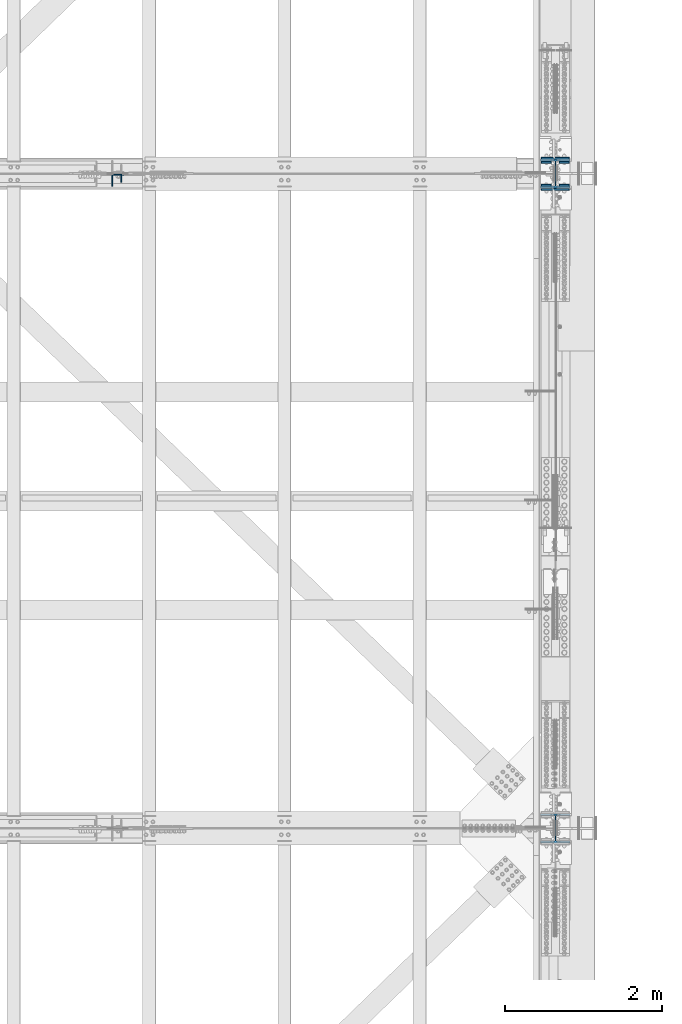
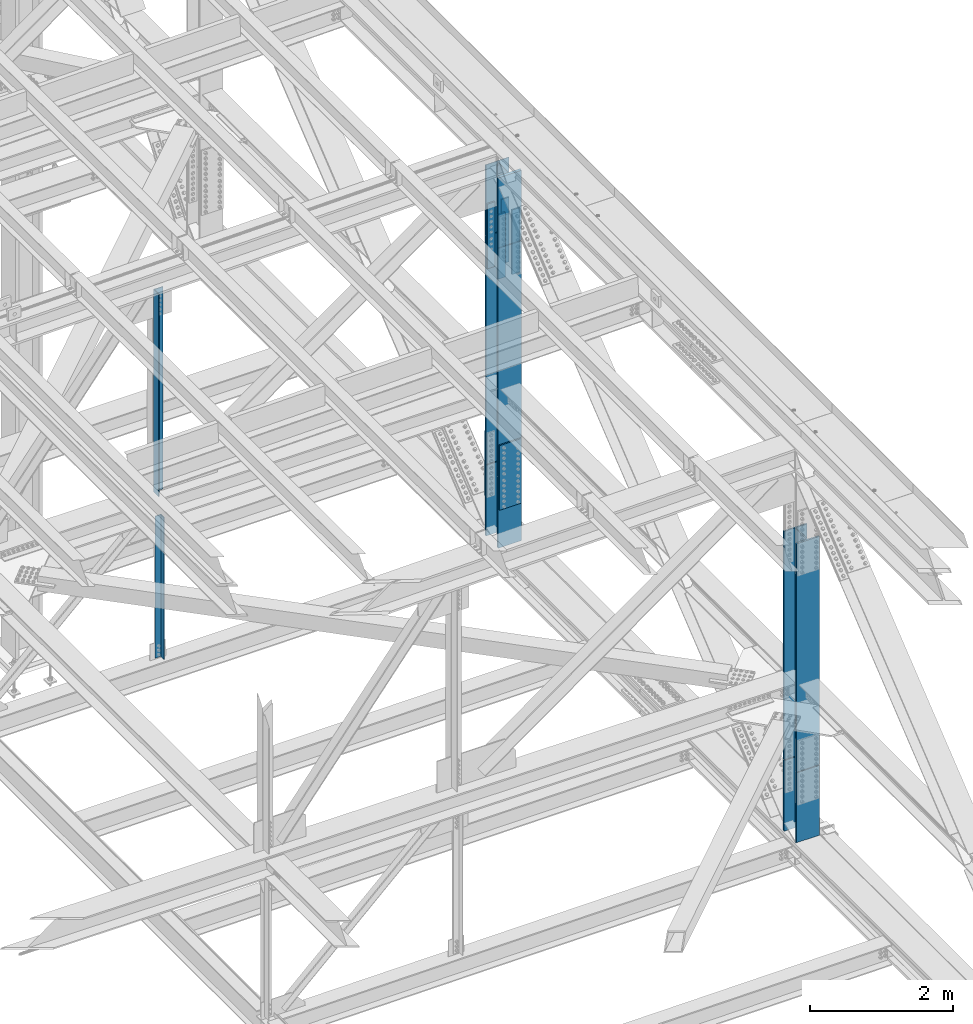
# One storey, part 1420 of 3843: 13 columns, 7 elements without a shape of their own.
"""IFC2X3 building model written with IfcOpenShell, lengths in millimetres."""

import ifcopenshell
import ifcopenshell.guid

model = None  # the IFC model being written
_history = None  # IfcOwnerHistory: only IFC2X3 demands one
_inside = {}  # id of a spatial element -> (the spatial element, [elements in it])
_under = {}  # id of a project, library or spatial element -> (it, [spatial elements below it])
_declared = {}  # id of a project -> (the project, [libraries it declares])
_typed = {}  # id of a type object -> (the type object, [elements of that type])
_made_of = {}  # id of a material, layer set ... -> (it, [elements and type objects made of it])


def new_model(schema):
    """Start an empty IFC model of exactly this schema.

    Asked for "IFC4X3", IfcOpenShell would pick the latest addendum, in which some entities
    have other attributes; the version numbers below select the first issue.
    IFC2X3 requires an IfcOwnerHistory on every rooted entity: one is made here for all.
    """
    global model, _history
    if schema == "IFC4X3":
        model = ifcopenshell.file(schema_version=(4, 3, 0, 0))
    else:
        model = ifcopenshell.file(schema=schema)
    _inside.clear()
    _under.clear()
    _declared.clear()
    _typed.clear()
    _made_of.clear()
    _history = None
    if model.schema == "IFC2X3":
        org = make("IfcOrganization", Name="unknown")
        user = make(
            "IfcPersonAndOrganization",
            ThePerson=make("IfcPerson", FamilyName="unknown"),
            TheOrganization=org,
        )
        app = make(
            "IfcApplication",
            ApplicationDeveloper=org,
            Version="unknown",
            ApplicationFullName="unknown",
            ApplicationIdentifier="unknown",
        )
        _history = make(
            "IfcOwnerHistory",
            OwningUser=user,
            OwningApplication=app,
            ChangeAction="ADDED",
            CreationDate=0,
        )
    return model


def make(cls, **values):
    """One entity of the class cls with the attributes given. An attribute that is None is left unset."""
    return model.create_entity(
        cls, **{name: value for name, value in values.items() if value is not None}
    )


def rooted(cls, **values):
    """An entity with a GlobalId (a new one), such as an element, a storey or a relation."""
    return make(cls, GlobalId=ifcopenshell.guid.new(), OwnerHistory=_history, **values)


def si_unit(unit_type, name, prefix=None):
    """IfcSIUnit, for example si_unit("LENGTHUNIT", "METRE", prefix="MILLI")."""
    return make("IfcSIUnit", UnitType=unit_type, Prefix=prefix, Name=name)


def assignment(units):
    """IfcUnitAssignment: the units of a project."""
    return None if units is None else make("IfcUnitAssignment", Units=units)


def point(xyz):
    """IfcCartesianPoint."""
    return None if xyz is None else make("IfcCartesianPoint", Coordinates=xyz)


def direction(xyz):
    """IfcDirection."""
    return None if xyz is None else make("IfcDirection", DirectionRatios=xyz)


def frame(location, z_axis=None, x_axis=None):
    """IfcAxis2Placement3D, a coordinate frame: its origin and axes. An axis left out is left unset."""
    return make(
        "IfcAxis2Placement3D",
        Location=point(location),
        Axis=direction(z_axis),
        RefDirection=direction(x_axis),
    )


def origin_with_axes():
    """The frame at (0, 0, 0) with the z axis (0, 0, 1) and the x axis (1, 0, 0) written out."""
    return frame((0.0, 0.0, 0.0), z_axis=(0.0, 0.0, 1.0), x_axis=(1.0, 0.0, 0.0))


def place(relative_to, where):
    """IfcLocalPlacement: puts the frame where relative to a parent placement (None: the world)."""
    return make(
        "IfcLocalPlacement", PlacementRelTo=relative_to, RelativePlacement=where
    )


def context(
    kind, dimensions, precision=None, world=None, true_north=None, identifier=None
):
    """IfcGeometricRepresentationContext, for example the 3D "Model" context."""
    return make(
        "IfcGeometricRepresentationContext",
        ContextIdentifier=identifier,
        ContextType=kind,
        CoordinateSpaceDimension=dimensions,
        Precision=precision,
        WorldCoordinateSystem=world,
        TrueNorth=true_north,
    )


def subcontext(parent, identifier, kind, view, scale=None):
    """IfcGeometricRepresentationSubContext, for example "Body" below "Model"."""
    return make(
        "IfcGeometricRepresentationSubContext",
        ContextIdentifier=identifier,
        ContextType=kind,
        ParentContext=parent,
        TargetScale=scale,
        TargetView=view,
    )


def project(units=None, contexts=None):
    """IfcProject with its units and contexts."""
    return rooted(
        "IfcProject",
        Name="project",
        RepresentationContexts=contexts,
        UnitsInContext=assignment(units),
    )


def spatial(cls, under=None, at=None, **own):
    """A site, building, storey or space (cls), placed at a placement, below another one or the project."""
    s = rooted(cls, ObjectPlacement=at, **own)
    if under is not None:
        _under.setdefault(under.id(), (under, []))[1].append(s)
    return s


def faces_of(points, faces, orient=None, outer=None):
    """IfcFace entities. A face is a list of loops; a loop is a list of indices into points, from 0.

    orient and outer hold one flag for each loop. By default every Orientation is true, the
    first loop of a face is its IfcFaceOuterBound and the others are IfcFaceBound.
    """
    made = []
    for i, loops in enumerate(faces):
        bounds = []
        for j, loop in enumerate(loops):
            is_outer = j == 0 if outer is None else outer[i][j]
            bounds.append(
                make(
                    "IfcFaceOuterBound" if is_outer else "IfcFaceBound",
                    Bound=make("IfcPolyLoop", Polygon=[points[k] for k in loop]),
                    Orientation=True if orient is None else orient[i][j],
                )
            )
        made.append(make("IfcFace", Bounds=bounds))
    return made


def faceted_brep(points, faces, orient=None, outer=None, voids=None):
    """IfcFacetedBrep: a solid bounded by flat faces; with voids (closed shells), ...WithVoids."""
    shared = [point(p) for p in points]
    hull = make("IfcClosedShell", CfsFaces=faces_of(shared, faces, orient, outer))
    if voids is None:
        return make("IfcFacetedBrep", Outer=hull)
    return make(
        "IfcFacetedBrepWithVoids",
        Outer=hull,
        Voids=[
            make(cls, CfsFaces=faces_of(shared, fs, o, b)) for cls, fs, o, b in voids
        ],
    )


def shape(context_of_items, identifier, shape_type, items):
    """IfcShapeRepresentation: the items that make up one representation, for example the "Body"."""
    return make(
        "IfcShapeRepresentation",
        ContextOfItems=context_of_items,
        RepresentationIdentifier=identifier,
        RepresentationType=shape_type,
        Items=items,
    )


def material(Name=None, Category=None):
    """IfcMaterial."""
    return make("IfcMaterial", Name=Name, Category=Category)


def made_of(thing, what):
    """Note that an element or type object is made of a material, layer set ...; save() writes the relation."""
    if what is not None:
        _made_of.setdefault(what.id(), (what, []))[1].append(thing)
    return thing


def type_object(cls, material=None, **own):
    """A type object (cls), such as IfcWallType, which elements share."""
    return made_of(rooted(cls, **own), material)


def element(
    cls,
    number,
    at=None,
    inside=None,
    cuts=None,
    type_object=None,
    material=None,
    context=None,
    identifier="Body",
    shape_type=None,
    held_by="IfcProductDefinitionShape",
    body=None,
    shapes=None,
    **own,
):
    """One element of the class cls, such as IfcWall. Its Tag is "e" and its number.

    at: its placement. inside: the storey or other place that contains it. cuts: it is an
    opening in that element (IfcRelVoidsElement). A single representation is given by context,
    identifier, shape_type and body (its items); several are given by shapes. held_by: the class
    of the entity that holds the representations. save() writes the other relations.
    """
    e = rooted(cls, Tag="e%d" % number, ObjectPlacement=at, **own)
    if body is not None:
        shapes = [shape(context, identifier, shape_type, body)]
    if shapes is not None:
        e.Representation = make(held_by, Representations=shapes)
    if inside is not None:
        _inside.setdefault(inside.id(), (inside, []))[1].append(e)
    if cuts is not None:
        rooted(
            "IfcRelVoidsElement", RelatingBuildingElement=cuts, RelatedOpeningElement=e
        )
    if type_object is not None:
        _typed.setdefault(type_object.id(), (type_object, []))[1].append(e)
    return made_of(e, material)


def aggregate(whole, parts):
    """IfcRelAggregates: a whole, such as a stair, and the parts it consists of."""
    return rooted("IfcRelAggregates", RelatingObject=whole, RelatedObjects=parts)


def save(model, path):
    """Write the relations noted so far, then the file.

    IfcRelAggregates (storeys below a building ...), IfcRelContainedInSpatialStructure (elements
    in a storey), IfcRelDefinesByType, IfcRelAssociatesMaterial and IfcRelDeclares: one each for
    every whole, place, type object, material and project.
    """
    for whole, parts in _under.values():
        aggregate(whole, parts)
    for where, things in _inside.values():
        rooted(
            "IfcRelContainedInSpatialStructure",
            RelatedElements=things,
            RelatingStructure=where,
        )
    for kind, things in _typed.values():
        rooted("IfcRelDefinesByType", RelatedObjects=things, RelatingType=kind)
    for what, things in _made_of.values():
        rooted("IfcRelAssociatesMaterial", RelatedObjects=things, RelatingMaterial=what)
    for by, libraries in _declared.values():
        rooted("IfcRelDeclares", RelatingContext=by, RelatedDefinitions=libraries)
    model.write(path)


model = new_model("IFC2X3")

# Units and contexts
model_context = context("Model", 3, precision=1e-05, world=origin_with_axes())
body_context = subcontext(model_context, "Body", "Model", "MODEL_VIEW")
ifc_project = project(units=[si_unit("LENGTHUNIT", "METRE", prefix="MILLI"), si_unit("AREAUNIT", "SQUARE_METRE"), si_unit("VOLUMEUNIT", "CUBIC_METRE"), si_unit("MASSUNIT", "GRAM", prefix="KILO"), si_unit("TIMEUNIT", "SECOND"), si_unit("PLANEANGLEUNIT", "RADIAN"), si_unit("SOLIDANGLEUNIT", "STERADIAN"), si_unit("THERMODYNAMICTEMPERATUREUNIT", "DEGREE_CELSIUS"), si_unit("LUMINOUSINTENSITYUNIT", "LUMEN")], contexts=[model_context])

# Site, building, storey
site_placement = place(None, origin_with_axes())
site = spatial("IfcSite", under=ifc_project, at=site_placement, CompositionType="ELEMENT")
building_placement = place(site_placement, origin_with_axes())
building = spatial("IfcBuilding", under=site, at=building_placement, Name="Undefined", CompositionType="ELEMENT")
storey_placement = place(building_placement, origin_with_axes())
storey = spatial("IfcBuildingStorey", under=building, at=storey_placement, Name="Undefined", CompositionType="ELEMENT", Elevation=0.0)

# Assembly, column
assembly_1_placement = place(storey_placement, origin_with_axes())
assembly_1 = element("IfcElementAssembly", 1, at=assembly_1_placement, inside=storey, Name="ANGLE", AssemblyPlace="NOTDEFINED", PredefinedType="RIGID_FRAME")
ifc_material_1 = material(Name="STEEL/A572-50")
column_type_1 = type_object("IfcColumnType", Name="L4X4X3/8", PredefinedType="NOTDEFINED")
column_1_placement = place(assembly_1_placement, frame((80060.7999999579, 75568.175, 39465.2385299534), z_axis=(-1.0, 0.0, 0.0), x_axis=(0.0, 0.0, 1.0)))
column_1 = element("IfcColumn", 2, at=column_1_placement, type_object=column_type_1, material=ifc_material_1, Name="ANGLE", ObjectType="L4X4X3/8", context=body_context, shape_type="Brep", body=[
    faceted_brep([(203.510731785107, 50.8000000000029, -50.8000000000029), (203.510731785107, 50.8000000000029, 50.8000000000029), (2631.72677430857, 50.8000000000029, 50.8000000000029), (2631.72677430857, 50.8000000000029, -50.8000000000029), (203.510731785107, 41.2749999999942, 50.8000000000029), (2631.72677430857, 41.2749999999942, 50.8000000000029), (203.510731785107, 41.2749999999942, -41.2749999999942), (2631.72677430857, 41.2749999999942, -41.2749999999942), (203.510731785107, -50.8000000000029, -41.2749999999942), (2631.72677430857, -50.8000000000029, -41.2749999999942), (203.510731785107, -50.8000000000029, -50.8000000000029), (2631.72677430857, -50.8000000000029, -50.8000000000029)], [[[0, 1, 2, 3]], [[1, 4, 5, 2]], [[4, 6, 7, 5]], [[6, 8, 9, 7]], [[8, 10, 11, 9]], [[10, 0, 3, 11]], [[5, 7, 9, 11, 3, 2]], [[10, 8, 6, 4, 1, 0]]]),
])
aggregate(assembly_1, [column_1])

# Assembly, columns
assembly_2_placement = place(storey_placement, origin_with_axes())
assembly_2 = element("IfcElementAssembly", 3, at=assembly_2_placement, inside=storey, Name="BEAM", AssemblyPlace="NOTDEFINED", PredefinedType="RIGID_FRAME")
column_type_2 = type_object("IfcColumnType", PredefinedType="NOTDEFINED")
column_2_placement = place(assembly_2_placement, frame((85534.5, 75480.8623822225, 44321.8444674401), z_axis=(1.0, 0.0, 0.0), x_axis=(0.0, 0.0, 1.0)))
column_2 = element("IfcColumn", 4, at=column_2_placement, type_object=column_type_2, material=ifc_material_1, Name="PLATE", context=body_context, shape_type="Brep", body=[
    faceted_brep([(-4.36557456851006e-11, 12.7000000000116, -63.5), (-4.36557456851006e-11, 12.7000000000116, 63.5), (1104.90000001677, 12.7000000017251, 63.5), (1104.90000001677, 12.7000000017251, -63.5), (1.45519152283669e-11, -12.700000000008, 63.5), (1104.90000001682, -12.6999999982909, 63.5), (1.45519152283669e-11, -12.700000000008, -63.5), (1104.90000001682, -12.6999999982909, -63.5)], [[[0, 1, 2, 3]], [[1, 4, 5, 2]], [[4, 6, 7, 5]], [[6, 0, 3, 7]], [[5, 7, 3, 2]], [[6, 4, 1, 0]]]),
])
column_3_placement = place(assembly_2_placement, frame((85534.5, 75776.1373007486, 44321.8444376159), z_axis=(1.0, 0.0, 0.0), x_axis=(0.0, 0.0, 1.0)))
column_3 = element("IfcColumn", 5, at=column_3_placement, type_object=column_type_2, material=ifc_material_1, Name="PLATE", context=body_context, shape_type="Brep", body=[
    faceted_brep([(-4.36557456851006e-11, 12.7000000000116, -63.5), (-4.36557456851006e-11, 12.7000000000116, 63.5), (1104.90000001677, 12.7000000017251, 63.5), (1104.90000001677, 12.7000000017251, -63.5), (1.45519152283669e-11, -12.700000000008, 63.5), (1104.90000001682, -12.6999999982909, 63.5), (1.45519152283669e-11, -12.700000000008, -63.5), (1104.90000001682, -12.6999999982909, -63.5)], [[[0, 1, 2, 3]], [[1, 4, 5, 2]], [[4, 6, 7, 5]], [[6, 0, 3, 7]], [[5, 7, 3, 2]], [[6, 4, 1, 0]]]),
])
column_4_placement = place(assembly_2_placement, frame((85763.1, 75480.8623822225, 44321.8444674401), z_axis=(1.0, 0.0, 0.0), x_axis=(0.0, 0.0, 1.0)))
column_4 = element("IfcColumn", 6, at=column_4_placement, type_object=column_type_2, material=ifc_material_1, Name="PLATE", context=body_context, shape_type="Brep", body=[
    faceted_brep([(-4.36557456851006e-11, 12.7000000000116, -63.5), (-4.36557456851006e-11, 12.7000000000116, 63.5), (1104.90000001677, 12.7000000017251, 63.5), (1104.90000001677, 12.7000000017251, -63.5), (1.45519152283669e-11, -12.700000000008, 63.5), (1104.90000001682, -12.6999999982909, 63.5), (1.45519152283669e-11, -12.700000000008, -63.5), (1104.90000001682, -12.6999999982909, -63.5)], [[[0, 1, 2, 3]], [[1, 4, 5, 2]], [[4, 6, 7, 5]], [[6, 0, 3, 7]], [[5, 7, 3, 2]], [[6, 4, 1, 0]]]),
])
column_5_placement = place(assembly_2_placement, frame((85763.1, 75776.1373059021, 44321.8444376159), z_axis=(1.0, 0.0, 0.0), x_axis=(0.0, 0.0, 1.0)))
column_5 = element("IfcColumn", 7, at=column_5_placement, type_object=column_type_2, material=ifc_material_1, Name="PLATE", context=body_context, shape_type="Brep", body=[
    faceted_brep([(-4.36557456851006e-11, 12.7000000000116, -63.5), (-4.36557456851006e-11, 12.7000000000116, 63.5), (1104.90000001677, 12.7000000017251, 63.5), (1104.90000001677, 12.7000000017251, -63.5), (1.45519152283669e-11, -12.700000000008, 63.5), (1104.90000001682, -12.6999999982909, 63.5), (1.45519152283669e-11, -12.700000000008, -63.5), (1104.90000001682, -12.6999999982909, -63.5)], [[[0, 1, 2, 3]], [[1, 4, 5, 2]], [[4, 6, 7, 5]], [[6, 0, 3, 7]], [[5, 7, 3, 2]], [[6, 4, 1, 0]]]),
])

# Assembly, column
assembly_3_placement = place(storey_placement, origin_with_axes())
assembly_3 = element("IfcElementAssembly", 8, at=assembly_3_placement, inside=storey, Name="ANGLE", AssemblyPlace="NOTDEFINED", PredefinedType="RIGID_FRAME")
column_type_3 = type_object("IfcColumnType", Name="L6X6X1/2", PredefinedType="NOTDEFINED")
column_6_placement = place(assembly_3_placement, frame((80060.8, 75542.775, 42313.9416734368), z_axis=(0.0, -1.0, 0.0), x_axis=(0.0, 0.0, 1.0)))
column_6 = element("IfcColumn", 9, at=column_6_placement, type_object=column_type_3, material=ifc_material_1, Name="ANGLE", ObjectType="L6X6X1/2", context=body_context, shape_type="Brep", body=[
    faceted_brep([(210.389274784269, 76.1999999999971, -76.1999999999971), (210.389274784269, 76.1999999999971, 76.1999999999971), (3669.54954076916, 76.1999999999971, 76.1999999999971), (3669.54954076916, 76.1999999999971, -76.1999999999971), (210.389274784269, 63.5, 76.1999999999971), (3669.54954076916, 63.5, 76.1999999999971), (210.389274784269, 63.5, -63.5), (3669.54954076916, 63.5, -63.5), (210.389274784269, -76.1999999999971, -63.5), (3669.54954076916, -76.1999999999971, -63.5), (210.389274784269, -76.1999999999971, -76.1999999999971), (3669.54954076916, -76.1999999999971, -76.1999999999971)], [[[0, 1, 2, 3]], [[1, 4, 5, 2]], [[4, 6, 7, 5]], [[6, 8, 9, 7]], [[8, 10, 11, 9]], [[10, 0, 3, 11]], [[5, 7, 9, 11, 3, 2]], [[10, 8, 6, 4, 1, 0]]]),
])
aggregate(assembly_3, [column_6])

# Assembly, columns
assembly_4_placement = place(storey_placement, origin_with_axes())
assembly_4 = element("IfcElementAssembly", 10, at=assembly_4_placement, inside=storey, Name="BEAM", AssemblyPlace="NOTDEFINED", PredefinedType="RIGID_FRAME")
column_type_4 = type_object("IfcColumnType", PredefinedType="NOTDEFINED")
column_7_placement = place(assembly_4_placement, frame((85648.8, 75430.0625000002, 40403.8839713305), z_axis=(-1.0, 0.0, 0.0), x_axis=(0.0, 0.0, 1.0)))
column_7 = element("IfcColumn", 11, at=column_7_placement, type_object=column_type_4, material=ifc_material_1, Name="PLATE", context=body_context, shape_type="Brep", body=[
    faceted_brep([(-1.45519152283669e-11, 12.7000000000025, -177.800000000003), (-1.45519152283669e-11, 12.7000000000025, 177.800000000003), (1104.90000001682, 12.7000000017051, 177.800000000003), (1104.90000001682, 12.7000000017051, -177.800000000003), (4.36557456851006e-11, -12.7000000000171, 177.800000000003), (1104.90000001686, -12.6999999983072, 177.800000000003), (4.36557456851006e-11, -12.7000000000171, -177.800000000003), (1104.90000001686, -12.6999999983072, -177.800000000003)], [[[0, 1, 2, 3]], [[1, 4, 5, 2]], [[4, 6, 7, 5]], [[6, 0, 3, 7]], [[5, 7, 3, 2]], [[6, 4, 1, 0]]]),
])
column_8_placement = place(assembly_4_placement, frame((85648.8, 75826.9375000002, 40403.8839713305), z_axis=(-1.0, 0.0, 0.0), x_axis=(0.0, 0.0, 1.0)))
column_8 = element("IfcColumn", 12, at=column_8_placement, type_object=column_type_4, material=ifc_material_1, Name="PLATE", context=body_context, shape_type="Brep", body=[
    faceted_brep([(-1.45519152283669e-11, 12.7000000000025, -177.800000000003), (-1.45519152283669e-11, 12.7000000000025, 177.800000000003), (1104.90000001682, 12.7000000017051, 177.800000000003), (1104.90000001682, 12.7000000017051, -177.800000000003), (4.36557456851006e-11, -12.7000000000171, 177.800000000003), (1104.90000001686, -12.6999999983072, 177.800000000003), (4.36557456851006e-11, -12.7000000000171, -177.800000000003), (1104.90000001686, -12.6999999983072, -177.800000000003)], [[[0, 1, 2, 3]], [[1, 4, 5, 2]], [[4, 6, 7, 5]], [[6, 0, 3, 7]], [[5, 7, 3, 2]], [[6, 4, 1, 0]]]),
])

# Column
ifc_material_2 = material(Name="STEEL/A992")
column_type_5 = type_object("IfcColumnType", Name="W14X132", PredefinedType="NOTDEFINED")
column_9_placement = place(assembly_2_placement, frame((85648.8, 75628.4998616975, 44874.294452528), z_axis=(0.0, 1.0, 0.0), x_axis=(0.0, 0.0, 1.0)))
column_9 = element("IfcColumn", 13, at=column_9_placement, type_object=column_type_5, material=ifc_material_2, Name="COLUMN", ObjectType="W14X132", context=body_context, shape_type="Brep", body=[
    faceted_brep([(1163.47275046445, 187.324999999997, -160.337499994377), (6.34999999999854, 187.324999999997, -160.337499999994), (6.34999999999854, 7.9375, -160.337499999994), (1163.47275046445, 7.9375, -160.337499994377), (1216.25693175628, 7.9375, -160.337499994115), (1216.25693175628, 187.324999999997, -160.337499994115), (1163.25387339722, 187.324999999997, 160.337500005626), (6.34999999999854, 187.324999999997, 160.337499999994), (6.34999999999854, 187.324999999997, 185.737500000003), (1201.32087227298, 187.324999999997, 185.737500005795), (1215.83975002835, 187.324999999997, 160.337500005873), (1163.25387339722, 7.9375, 160.337500005626), (6.34999999999854, 7.9375, 160.337499999994), (1215.83975002835, 7.9375, 160.337500005873), (1203.52163608688, 7.9375, -131.766481024737), (1159.20635003885, 7.9375, -131.79895580851), (1154.02788453551, 7.9375, -133.334161113235), (1150.5168297894, 7.9375, -137.438531328895), (1149.80218627131, 7.9375, -142.79228187773), (1152.11375184161, 7.9375, -147.673882528208), (1151.8840422614, 7.9375, 147.71786305157), (1149.57398253771, 7.9375, 142.834749782851), (1150.29113615173, 7.9375, 137.480605423989), (1153.80483636508, 7.9375, 133.377547791897), (1158.98492953692, 7.9375, 131.845292639176), (1203.18559827552, 7.9375, 131.841580194945), (1154.02788453551, -7.9375, -133.334161113235), (1159.20635003885, -7.9375, -131.79895580851), (1150.5168297894, -7.9375, -137.438531328895), (1149.80218627131, -7.9375, -142.79228187773), (1152.11375184161, -7.9375, -147.673882528208), (1163.47275046445, -7.9375, -160.337499994377), (6.34999999999854, -187.324999999997, -185.737500000003), (6.34999999999854, 187.324999999997, -185.737500000003), (1201.60570493688, 187.324999999997, -185.737499994197), (1201.60570493688, -187.324999999997, -185.737499994197), (1163.47275046445, -187.324999999997, -160.337499994377), (6.34999999999854, -187.324999999997, -160.337499999994), (1216.25693175628, -187.324999999997, -160.251952999606), (6.34999999999854, -7.9375, -160.337499999994), (1216.25693175628, -7.9375, -160.337499994115), (6.34999999999854, -7.9375, 160.337499999994), (6.34999999999854, -187.324999999997, 160.337499999994), (6.34999999999854, -187.324999999997, 185.737500000003), (1163.25387339722, -187.324999999997, 160.337500005626), (1163.25387339722, -7.9375, 160.337500005626), (1215.83976942373, -7.9375, 160.412031286905), (1215.83975002835, -187.324999999997, 160.425715785386), (1201.32087227298, -187.324999999997, 185.737500005795), (1151.8840422614, -7.9375, 147.71786305157), (1149.57398253771, -7.9375, 142.834749782851), (1150.29113615173, -7.9375, 137.480605423989), (1153.80483636508, -7.9375, 133.377547791897), (1158.98492953692, -7.9375, 131.845292639176), (1216.05420475623, -7.9375, 131.840503178915), (1216.05420475656, -4.93760635517538, 131.840502618797), (1216.21267654747, -4.75284506268508, -131.757180875153), (1216.21267654747, -7.9375, -131.757180875167)], [[[0, 1, 2, 3, 4, 5]], [[6, 7, 8, 9, 10]], [[11, 12, 7, 6, 10, 13]], [[14, 15, 16, 17, 18, 19, 3, 2, 12, 11, 20, 21, 22, 23, 24, 25]], [[26, 16, 15, 27]], [[28, 17, 16, 26]], [[29, 18, 17, 28]], [[30, 19, 18, 29]], [[31, 3, 19, 30]], [[32, 33, 34, 35]], [[36, 37, 32, 35, 38]], [[31, 39, 37, 36, 38, 40]], [[3, 31, 40, 4]], [[38, 35, 34, 5, 4, 40]], [[33, 1, 0, 5, 34]], [[32, 37, 39, 41, 42, 43, 8, 7, 12, 2, 1, 33]], [[44, 42, 41, 45, 46, 47]], [[43, 42, 44, 47, 48]], [[8, 43, 48, 9]], [[47, 46, 13, 10, 9, 48]], [[45, 11, 13, 46]], [[49, 20, 11, 45]], [[50, 21, 20, 49]], [[51, 22, 21, 50]], [[52, 23, 22, 51]], [[53, 24, 23, 52]], [[25, 24, 53, 54, 55]], [[14, 25, 55, 56]], [[27, 15, 14, 56, 57]], [[53, 52, 51, 50, 49, 45, 41, 39, 31, 30, 29, 28, 26, 27, 57, 54]], [[56, 55, 54, 57]]]),
])

aggregate(assembly_2, [column_2, column_3, column_4, column_5, column_9])

# Assembly, column
assembly_5_placement = place(storey_placement, origin_with_axes())
assembly_5 = element("IfcElementAssembly", 14, at=assembly_5_placement, inside=storey, Name="COLUMN", AssemblyPlace="NOTDEFINED", PredefinedType="RIGID_FRAME")
column_10_placement = place(assembly_5_placement, frame((85648.8, 75628.5000000064, 40956.3339713305), z_axis=(0.0, 1.0, 0.0), x_axis=(0.0, 0.0, 1.0)))
column_10 = element("IfcColumn", 15, at=column_10_placement, type_object=column_type_5, material=ifc_material_2, Name="COLUMN", ObjectType="W14X132", context=body_context, shape_type="Brep", body=[
    faceted_brep([(6.34999999999854, 187.324999999997, -185.737500000003), (6.34999999999854, 187.324999999997, -160.337499999994), (3911.61050299859, 187.324999999997, -160.337499989648), (3911.61050645299, 187.324999999997, -185.737499989642), (6.34999999999854, 7.9375, -160.337499999994), (3911.61050299859, 7.9375, -160.337499989648), (6.34999999999854, 7.9375, 160.337499999994), (3911.61045938679, 7.9375, 160.337500010355), (6.34999999999854, 187.324999999997, 160.337499999994), (3911.61045938679, 187.324999999997, 160.337500010355), (6.34999999999854, 187.324999999997, 185.737500000003), (3911.61045593239, 187.324999999997, 185.737500010364), (6.34999999999854, -187.324999999997, 185.737500000003), (3911.61045593239, -187.324999999997, 185.737500010364), (6.34999999999854, -187.324999999997, 160.337499999994), (3911.61045938679, -187.324999999997, 160.337500010355), (6.34999999999854, -7.9375, 160.337499999994), (3911.61045938679, -7.9375, 160.337500010355), (6.34999999999854, -7.9375, -160.337499999994), (3911.61050299859, -7.9375, -160.337499989648), (6.34999999999854, -187.324999999997, -160.337499999994), (3911.61050299859, -187.324999999997, -160.337499989648), (6.34999999999854, -187.324999999997, -185.737500000003), (3911.61050645299, -187.324999999997, -185.737499989642)], [[[0, 1, 2, 3]], [[1, 4, 5, 2]], [[4, 6, 7, 5]], [[6, 8, 9, 7]], [[8, 10, 11, 9]], [[10, 12, 13, 11]], [[12, 14, 15, 13]], [[14, 16, 17, 15]], [[16, 18, 19, 17]], [[18, 20, 21, 19]], [[20, 22, 23, 21]], [[22, 0, 3, 23]], [[5, 7, 9, 11, 13, 15, 17, 19, 21, 23, 3, 2]], [[22, 20, 18, 16, 14, 12, 10, 8, 6, 4, 1, 0]]]),
])
aggregate(assembly_5, [column_10])

assembly_6_placement = place(storey_placement, origin_with_axes())
assembly_6 = element("IfcElementAssembly", 16, at=assembly_6_placement, inside=storey, Name="COLUMN", AssemblyPlace="NOTDEFINED", PredefinedType="RIGID_FRAME")
column_11_placement = place(assembly_6_placement, frame((85648.8, 67271.9001383168, 40973.7785468794), z_axis=(0.0, 1.0, 0.0), x_axis=(0.0, 0.0, 1.0)))
column_11 = element("IfcColumn", 17, at=column_11_placement, type_object=column_type_5, material=ifc_material_2, Name="COLUMN", ObjectType="W14X132", context=body_context, shape_type="Brep", body=[
    faceted_brep([(6.34999999999854, 187.324999999997, -185.737500000003), (6.34999999999854, 187.324999999997, -160.337499999994), (3911.7174187256, 187.324999999997, -160.337499989662), (3911.7174196146, 187.324999999997, -185.737499989656), (6.34999999999854, 7.9375, -160.337499999994), (3911.7174187256, 7.9375, -160.337499989662), (6.34999999999854, 7.9375, 160.337499999994), (3911.71740750198, 7.9375, 160.337500010341), (6.34999999999854, 187.324999999997, 160.337499999994), (3911.71740750198, 187.324999999997, 160.337500010341), (6.34999999999854, 187.324999999997, 185.737500000003), (3911.71740661297, 187.324999999997, 185.737500010335), (6.34999999999854, -187.324999999997, 185.737500000003), (3911.71740661297, -187.324999999997, 185.737500010335), (6.34999999999854, -187.324999999997, 160.337499999994), (3911.71740750198, -187.324999999997, 160.337500010341), (6.34999999999854, -7.9375, 160.337499999994), (3911.71740750198, -7.9375, 160.337500010341), (6.34999999999854, -7.9375, -160.337499999994), (3911.7174187256, -7.9375, -160.337499989662), (6.34999999999854, -187.324999999997, -160.337499999994), (3911.7174187256, -187.324999999997, -160.337499989662), (6.34999999999854, -187.324999999997, -185.737500000003), (3911.7174196146, -187.324999999997, -185.737499989656)], [[[0, 1, 2, 3]], [[1, 4, 5, 2]], [[4, 6, 7, 5]], [[6, 8, 9, 7]], [[8, 10, 11, 9]], [[10, 12, 13, 11]], [[12, 14, 15, 13]], [[14, 16, 17, 15]], [[16, 18, 19, 17]], [[18, 20, 21, 19]], [[20, 22, 23, 21]], [[22, 0, 3, 23]], [[5, 7, 9, 11, 13, 15, 17, 19, 21, 23, 3, 2]], [[22, 20, 18, 16, 14, 12, 10, 8, 6, 4, 1, 0]]]),
])
aggregate(assembly_6, [column_11])

# Column
column_12_placement = place(assembly_4_placement, frame((85648.8, 75628.5000000002, 39529.1708651905), z_axis=(0.0, 1.0, 0.0), x_axis=(0.0, 0.0, 1.0)))
column_12 = element("IfcColumn", 18, at=column_12_placement, type_object=column_type_5, material=ifc_material_2, Name="COLUMN", ObjectType="W14X132", context=body_context, shape_type="Brep", body=[
    faceted_brep([(225.170169238896, -187.324999999997, 185.737500000003), (225.170169238896, 187.324999999997, 185.737500000003), (210.74229034999, 187.324999999997, 160.753574541493), (210.74229034999, -187.324999999997, 160.753574541493), (211.594915646056, -187.324999999997, -185.737500000003), (211.594915646056, 187.324999999997, -185.737500000003), (1420.81310613995, 187.324999999997, -185.737500000003), (1420.81310613995, -187.324999999997, -185.737500000003), (1420.81310613995, -7.9375, 160.337499999994), (1420.81310613995, -187.324999999997, 160.337499999994), (261.551234635721, -187.324999999997, 160.337499999994), (261.551234635721, -7.9375, 160.337499999994), (210.743238110284, -187.324999999997, 160.368422370491), (210.743238110284, 187.324999999997, 160.368422370491), (261.543235576712, 187.324999999997, 160.351368861157), (261.543235576712, -187.324999999997, 160.351368861157), (210.813554165652, -4.57788533711573, 131.793284273386), (223.32904749352, 7.9375, 131.789110690996), (224.33944347901, 7.9375, -131.741038430453), (211.462024104527, -4.93979331996525, -131.732847270789), (270.579468086777, -7.9375, -146.057129074368), (270.579468086777, 7.9375, -146.057129074368), (262.332334976534, 7.9375, -160.323912091786), (262.332334976534, -7.9375, -160.323912091786), (271.85812918684, -7.9375, -141.295552104624), (271.85812918684, 7.9375, -141.295552104624), (270.58481269169, -7.9375, -136.532543123845), (270.58481269169, 7.9375, -136.532543123845), (267.100670917243, -7.9375, -133.044227549923), (267.100670917243, 7.9375, -133.044227549923), (262.339189795552, -7.9375, -131.765209576828), (262.339189795552, 7.9375, -131.765209576828), (211.462024104527, -7.9375, -131.732847270789), (210.813554165652, -7.9375, 131.793284273386), (261.531680595217, -7.9375, 131.776371133892), (261.531680595217, 7.9375, 131.776371133892), (266.294386246751, -7.9375, 133.050764281725), (266.294386246751, 7.9375, 133.050764281725), (269.781906447832, -7.9375, 136.535681191119), (269.781906447832, 7.9375, 136.535681191119), (271.059855732907, -7.9375, 141.297433877175), (271.059855732907, 7.9375, 141.297433877175), (269.78584261208, -7.9375, 146.060241199186), (269.78584261208, 7.9375, 146.060241199186), (261.551234635721, 187.324999999997, 160.337499999994), (261.551234635721, 7.9375, 160.337499999994), (1420.81310613995, 187.324999999997, 160.337499999994), (1420.81310613995, 7.9375, 160.337499999994), (1420.81310613995, 7.9375, -160.337499999994), (1420.81310613995, 187.324999999997, -160.337499999994), (211.775119179911, 187.324999999997, -160.337499999994), (211.775119179911, 7.9375, -160.337499999994), (211.757806698392, 7.9375, -160.3070468511), (211.757806698392, -7.9375, -160.3070468511), (1420.81310613995, -7.9375, -160.337499999994), (211.775119179911, -7.9375, -160.337499999994), (1420.81310613995, -187.324999999997, -160.337499999994), (211.775119179911, -187.324999999997, -160.337499999994), (226.200334115223, -187.324999999997, -185.71186445764), (211.594840578444, -187.324999999997, -185.706993919623), (211.594840578444, 187.324999999997, -185.706993919623), (226.200334115223, 187.324999999997, -185.71186445764), (1420.81310613995, 187.324999999997, 185.737500000003), (1420.81310613995, -187.324999999997, 185.737500000003)], [[[0, 1, 2, 3]], [[4, 5, 6, 7]], [[8, 9, 10, 11]], [[12, 13, 14, 15]], [[16, 17, 18, 19]], [[20, 21, 22, 23]], [[24, 25, 21, 20]], [[26, 27, 25, 24]], [[28, 29, 27, 26]], [[30, 31, 29, 28]], [[32, 19, 18, 31, 30]], [[33, 16, 19, 32]], [[34, 35, 17, 16, 33]], [[36, 37, 35, 34]], [[38, 39, 37, 36]], [[40, 41, 39, 38]], [[42, 43, 41, 40]], [[11, 10, 15, 14, 44, 45, 43, 42]], [[46, 47, 45, 44]], [[48, 49, 50, 51]], [[22, 21, 25, 27, 29, 31, 18, 17, 35, 37, 39, 41, 43, 45, 47, 48, 51, 52]], [[23, 22, 52, 53]], [[54, 8, 11, 42, 40, 38, 36, 34, 33, 32, 30, 28, 26, 24, 20, 23, 53, 55]], [[56, 54, 55, 57]], [[4, 7, 56, 57, 58, 59]], [[5, 4, 59, 60]], [[58, 61, 60, 59]], [[57, 55, 53, 52, 51, 50, 61, 58]], [[49, 6, 5, 60, 61, 50]], [[48, 47, 46, 62, 63, 9, 8, 54, 56, 7, 6, 49]], [[12, 15, 10, 9, 63, 0, 3]], [[13, 12, 3, 2]], [[62, 46, 44, 14, 13, 2, 1]], [[63, 62, 1, 0]]]),
])

aggregate(assembly_4, [column_7, column_8, column_12])

# Assembly, column
assembly_7_placement = place(storey_placement, origin_with_axes())
assembly_7 = element("IfcElementAssembly", 19, at=assembly_7_placement, inside=storey, Name="BEAM", AssemblyPlace="NOTDEFINED", PredefinedType="RIGID_FRAME")
column_13_placement = place(assembly_7_placement, frame((85648.8, 67271.9000000001, 39546.6162840744), z_axis=(0.0, 1.0, 0.0), x_axis=(0.0, 0.0, 1.0)))
column_13 = element("IfcColumn", 20, at=column_13_placement, type_object=column_type_5, material=ifc_material_2, Name="COLUMN", ObjectType="W14X132", context=body_context, shape_type="Brep", body=[
    faceted_brep([(268.130126460346, -7.9375, -131.794812703389), (268.130126460346, 7.9375, -131.794812703389), (273.308873169677, 7.9375, -133.331612509151), (273.308873169677, -7.9375, -133.331612509151), (276.818971826244, 7.9375, -137.437751637757), (276.818971826244, -7.9375, -137.437751637757), (263.836095320999, 7.9375, -160.337499999194), (1420.81226280803, 7.9375, -160.337499995658), (1420.81226280803, 187.324999999997, -160.337499995658), (263.836095320999, 187.324999999997, -160.337499999194), (211.2445620219, 187.324999999997, -160.337499999354), (211.2445620219, 7.9375, -160.337499999354), (263.925200379934, -187.324999999997, 160.337500000809), (1420.81226280804, -187.324999999997, 160.33750000436), (1420.81226280803, -187.324999999997, 185.737500004354), (225.813224242658, -187.324999999997, 185.662345760647), (211.143250629961, -187.324999999997, 160.337500000634), (1420.81226280803, 187.324999999997, 185.737500004354), (225.813224242658, 187.324999999997, 185.737500000687), (1420.81226280804, 187.324999999997, 160.33750000436), (263.925200379934, 187.324999999997, 160.337500000809), (211.143250629961, 187.324999999997, 160.337500000634), (1420.81226280804, 7.9375, 160.33750000436), (263.925200379934, 7.9375, 160.337500000809), (211.143250629961, 7.9375, 160.337500000634), (276.860985340762, -7.9375, 137.481468717524), (276.860985340762, 7.9375, 137.481468717524), (273.346329475688, 7.9375, 133.380181791843), (273.346329475688, -7.9375, 133.380181791843), (277.580327656084, -7.9375, 142.834589950056), (277.580327656084, 7.9375, 142.834589950056), (275.273047635179, -7.9375, 147.718217618327), (275.273047635179, 7.9375, 147.718217618327), (263.925200379934, -7.9375, 160.337500000809), (211.143250629961, -7.9375, 160.337500000634), (1420.81226280804, -7.9375, 160.33750000436), (1420.81226280803, -7.9375, -160.337499995658), (1420.81226280803, -187.324999999997, -160.337499995658), (1420.81226280804, -187.324999999997, -185.737499995637), (1420.81226280804, 187.324999999997, -185.737499995637), (263.836095320999, -187.324999999997, -160.337499999194), (263.836095320999, -7.9375, -160.337499999194), (211.2445620219, -7.9375, -160.337499999354), (211.2445620219, -187.324999999997, -160.337499999354), (225.744681451572, -187.324999999997, -185.815810620348), (225.744681451572, 187.324999999997, -185.737499999304), (275.217083707314, -7.9375, -147.673607638208), (275.217083707314, 7.9375, -147.673607638208), (277.531427201226, -7.9375, -142.79252319783), (277.531427201226, 7.9375, -142.79252319783), (223.931851138441, 7.9375, -131.75231892), (223.848859080776, 7.9375, 131.855944108363), (268.166518492777, 7.9375, 131.849522300603), (268.166518492777, -7.9375, 131.849522300603), (211.157815813036, -7.9375, 131.857783001353), (211.063251439322, -7.9375, -131.739947032402), (211.063251439344, -4.93773947517911, -131.739946968184), (211.157815813036, -4.75457602609822, 131.857783015439)], [[[0, 1, 2, 3]], [[3, 2, 4, 5]], [[6, 7, 8, 9, 10, 11]], [[12, 13, 14, 15, 16]], [[14, 17, 18, 15]], [[17, 19, 20, 21, 18]], [[20, 19, 22, 23, 24, 21]], [[25, 26, 27, 28]], [[29, 30, 26, 25]], [[31, 32, 30, 29]], [[33, 23, 32, 31]], [[23, 33, 34, 24]], [[15, 18, 21, 24, 34, 16]], [[33, 35, 13, 12, 16, 34]], [[7, 22, 19, 17, 14, 13, 35, 36, 37, 38, 39, 8]], [[40, 37, 36, 41, 42, 43]], [[38, 37, 40, 43, 44]], [[39, 38, 44, 45]], [[9, 8, 39, 45, 10]], [[44, 43, 42, 11, 10, 45]], [[41, 6, 11, 42]], [[46, 47, 6, 41]], [[48, 49, 47, 46]], [[5, 4, 49, 48]], [[2, 1, 50, 51, 52, 27, 26, 30, 32, 23, 22, 7, 6, 47, 49, 4]], [[28, 27, 52, 53]], [[0, 3, 5, 48, 46, 41, 36, 35, 33, 31, 29, 25, 28, 53, 54, 55]], [[50, 1, 0, 55, 56]], [[51, 50, 56, 57]], [[53, 52, 51, 57, 54]], [[56, 55, 54, 57]]]),
])
aggregate(assembly_7, [column_13])

save(model, "model.ifc")
